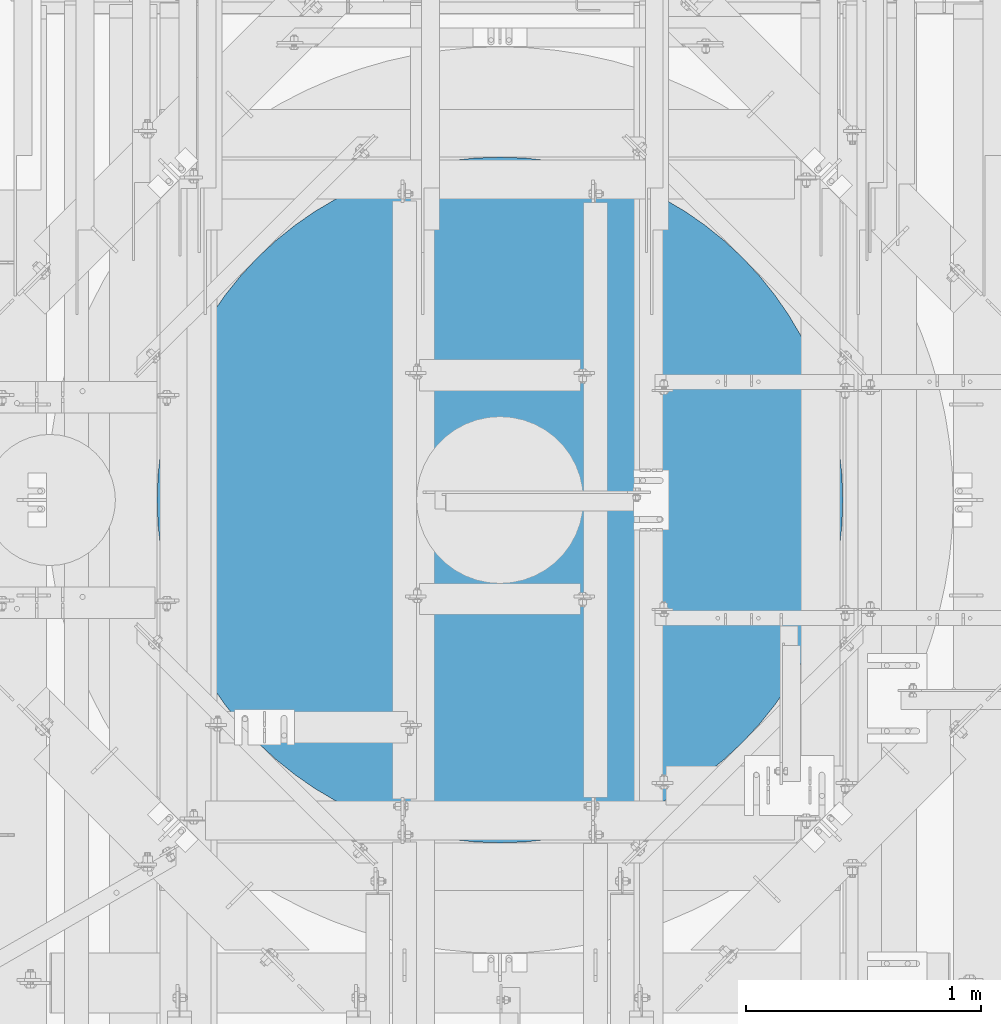
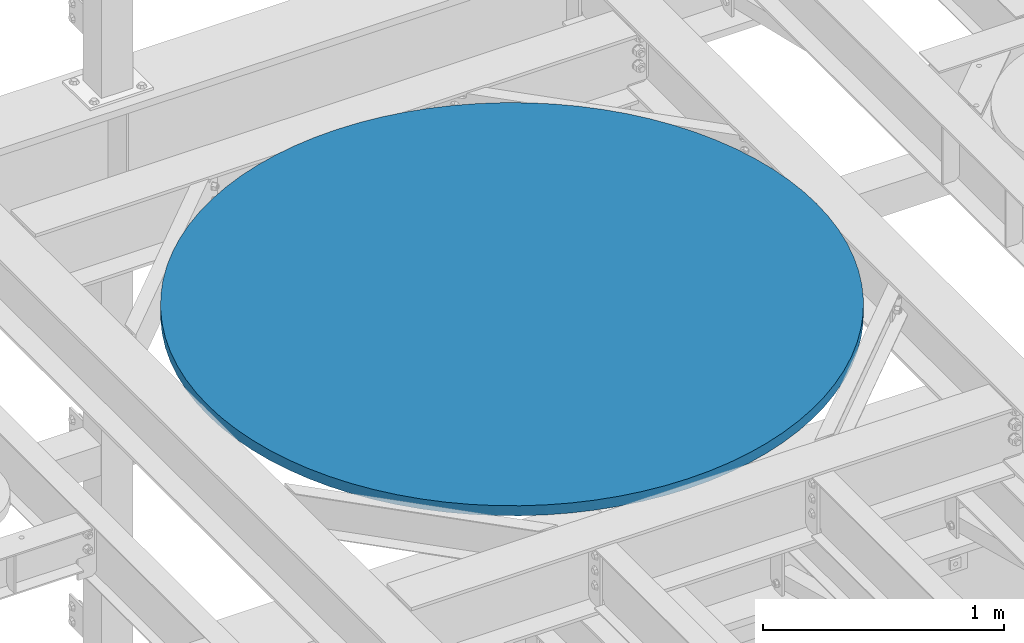
# One storey, part 744 of 1876: 1 column, 1 element without a shape of its own.
"""IFC2X3 building model written with IfcOpenShell, lengths in millimetres."""

from ifc_helpers import new_model, si_unit, frame, origin_with_axes, place, context, subcontext, project, spatial, faceted_brep, material, type_object, element, aggregate, save


model = new_model("IFC2X3")

# Units and contexts
model_context = context("Model", 3, precision=1e-05, world=origin_with_axes())
body_context = subcontext(model_context, "Body", "Model", "MODEL_VIEW")
ifc_project = project(units=[si_unit("LENGTHUNIT", "METRE", prefix="MILLI"), si_unit("AREAUNIT", "SQUARE_METRE"), si_unit("VOLUMEUNIT", "CUBIC_METRE"), si_unit("MASSUNIT", "GRAM", prefix="KILO"), si_unit("TIMEUNIT", "SECOND"), si_unit("PLANEANGLEUNIT", "RADIAN"), si_unit("SOLIDANGLEUNIT", "STERADIAN"), si_unit("THERMODYNAMICTEMPERATUREUNIT", "DEGREE_CELSIUS"), si_unit("LUMINOUSINTENSITYUNIT", "LUMEN")], contexts=[model_context])

# Site, building, storey
site_placement = place(None, origin_with_axes())
site = spatial("IfcSite", under=ifc_project, at=site_placement, CompositionType="ELEMENT")
building_placement = place(site_placement, origin_with_axes())
building = spatial("IfcBuilding", under=site, at=building_placement, Name="Undefined", CompositionType="ELEMENT")
storey_placement = place(building_placement, origin_with_axes())
storey = spatial("IfcBuildingStorey", under=building, at=storey_placement, Name="Undefined", CompositionType="ELEMENT", Elevation=0.0)

# Assembly, column
assembly_placement = place(storey_placement, origin_with_axes())
assembly = element("IfcElementAssembly", 1, at=assembly_placement, inside=storey, Name="COLUMN", AssemblyPlace="NOTDEFINED", PredefinedType="REINFORCEMENT_UNIT")
ifc_material = material(Name="CONCRETE/3000")
column_type = type_object("IfcColumnType", PredefinedType="NOTDEFINED")
column_placement = place(assembly_placement, frame((3187.7, 11480.8, 8128.0), z_axis=(-1.0, 0.0, 0.0), x_axis=(0.0, 0.0, 1.0)))
column = element("IfcColumn", 2, at=column_placement, type_object=column_type, material=ifc_material, Name="COLUMN", context=body_context, shape_type="Brep", body=[
    faceted_brep([(0.0, -1460.5, 0.0), (0.0, -1456.77881338828, -104.190877062479), (50.7999999999993, -1456.77881338828, -104.190877062479), (50.7999999999993, -1460.5, 0.0), (0.0, -1445.6342158671, -207.850821298133), (50.7999999999993, -1445.6342158671, -207.850821298133), (0.0, -1427.12299775088, -310.451605392123), (50.7999999999993, -1427.12299775088, -310.451605392123), (0.0, -1401.33948796397, -411.470399266908), (50.7999999999993, -1401.33948796397, -411.470399266908), (0.0, -1368.41507336215, -510.392434304484), (50.7999999999993, -1368.41507336215, -510.392434304484), (0.0, -1328.51752921527, -606.713626489255), (50.7999999999993, -1328.51752921527, -606.713626489255), (0.0, -1281.85016426298, -699.943145104643), (50.7999999999993, -1281.85016426298, -699.943145104643), (0.0, -1228.65078469994, -789.6059138939), (50.7999999999993, -1228.65078469994, -789.6059138939), (0.0, -1169.19048237003, -875.245031939823), (50.7999999999993, -1169.19048237003, -875.245031939823), (0.0, -1103.77225334439, -956.424101927088), (50.7999999999993, -1103.77225334439, -956.424101927088), (0.0, -1032.72945392295, -1032.72945392295), (50.7999999999993, -1032.72945392295, -1032.72945392295), (0.0, -956.424101927088, -1103.77225334439), (50.7999999999993, -956.424101927088, -1103.77225334439), (0.0, -875.245031939821, -1169.19048237003), (50.7999999999993, -875.245031939821, -1169.19048237003), (0.0, -789.6059138939, -1228.65078469994), (50.7999999999993, -789.6059138939, -1228.65078469994), (0.0, -699.943145104642, -1281.85016426298), (50.7999999999993, -699.943145104642, -1281.85016426298), (0.0, -606.713626489254, -1328.51752921527), (50.7999999999993, -606.713626489254, -1328.51752921527), (0.0, -510.392434304484, -1368.41507336215), (50.7999999999993, -510.392434304484, -1368.41507336215), (0.0, -411.470399266907, -1401.33948796397), (50.7999999999993, -411.470399266907, -1401.33948796397), (0.0, -310.451605392123, -1427.12299775088), (50.7999999999993, -310.451605392123, -1427.12299775088), (0.0, -207.850821298132, -1445.6342158671), (50.7999999999993, -207.850821298132, -1445.6342158671), (0.0, -104.19087706248, -1456.77881338828), (50.7999999999993, -104.19087706248, -1456.77881338828), (0.0, 0.0, -1460.5), (50.7999999999993, 0.0, -1460.5), (0.0, 104.190877062478, -1456.77881338828), (50.7999999999993, 104.190877062478, -1456.77881338828), (0.0, 207.850821298132, -1445.6342158671), (50.7999999999993, 207.850821298132, -1445.6342158671), (0.0, 310.451605392123, -1427.12299775088), (50.7999999999993, 310.451605392123, -1427.12299775088), (0.0, 411.470399266907, -1401.33948796397), (50.7999999999993, 411.470399266907, -1401.33948796397), (0.0, 510.392434304484, -1368.41507336215), (50.7999999999993, 510.392434304484, -1368.41507336215), (0.0, 606.713626489254, -1328.51752921527), (50.7999999999993, 606.713626489254, -1328.51752921527), (0.0, 699.943145104644, -1281.85016426298), (50.7999999999993, 699.943145104644, -1281.85016426298), (0.0, 789.6059138939, -1228.65078469994), (50.7999999999993, 789.6059138939, -1228.65078469994), (0.0, 875.245031939823, -1169.19048237003), (50.7999999999993, 875.245031939823, -1169.19048237003), (0.0, 956.424101927088, -1103.77225334439), (50.7999999999993, 956.424101927088, -1103.77225334439), (0.0, 1032.72945392295, -1032.72945392295), (50.7999999999993, 1032.72945392295, -1032.72945392295), (0.0, 1103.77225334439, -956.424101927088), (50.7999999999993, 1103.77225334439, -956.424101927088), (0.0, 1169.19048237003, -875.245031939822), (50.7999999999993, 1169.19048237003, -875.245031939822), (0.0, 1228.65078469994, -789.6059138939), (50.7999999999993, 1228.65078469994, -789.6059138939), (0.0, 1281.85016426298, -699.943145104643), (50.7999999999993, 1281.85016426298, -699.943145104643), (0.0, 1328.51752921527, -606.713626489255), (50.7999999999993, 1328.51752921527, -606.713626489255), (0.0, 1368.41507336215, -510.392434304483), (50.7999999999993, 1368.41507336215, -510.392434304483), (0.0, 1401.33948796397, -411.470399266907), (50.7999999999993, 1401.33948796397, -411.470399266907), (0.0, 1427.12299775088, -310.451605392122), (50.7999999999993, 1427.12299775088, -310.451605392122), (0.0, 1445.6342158671, -207.850821298133), (50.7999999999993, 1445.6342158671, -207.850821298133), (0.0, 1456.77881338828, -104.190877062479), (50.7999999999993, 1456.77881338828, -104.190877062479), (0.0, 1460.5, 0.0), (50.7999999999993, 1460.5, 0.0), (0.0, 1456.77881338828, 104.190877062479), (50.7999999999993, 1456.77881338828, 104.190877062479), (0.0, 1445.6342158671, 207.850821298133), (50.7999999999993, 1445.6342158671, 207.850821298133), (0.0, 1427.12299775088, 310.451605392122), (50.7999999999993, 1427.12299775088, 310.451605392122), (0.0, 1401.33948796397, 411.470399266908), (50.7999999999993, 1401.33948796397, 411.470399266908), (0.0, 1368.41507336215, 510.392434304483), (50.7999999999993, 1368.41507336215, 510.392434304483), (0.0, 1328.51752921527, 606.713626489255), (50.7999999999993, 1328.51752921527, 606.713626489255), (0.0, 1281.85016426298, 699.943145104643), (50.7999999999993, 1281.85016426298, 699.943145104643), (0.0, 1228.65078469994, 789.605913893901), (50.7999999999993, 1228.65078469994, 789.605913893901), (0.0, 1169.19048237003, 875.245031939822), (50.7999999999993, 1169.19048237003, 875.245031939822), (0.0, 1103.77225334439, 956.424101927089), (50.7999999999993, 1103.77225334439, 956.424101927089), (0.0, 1032.72945392295, 1032.72945392295), (50.7999999999993, 1032.72945392295, 1032.72945392295), (0.0, 956.424101927088, 1103.77225334439), (50.7999999999993, 956.424101927088, 1103.77225334439), (0.0, 875.245031939823, 1169.19048237003), (50.7999999999993, 875.245031939823, 1169.19048237003), (0.0, 789.6059138939, 1228.65078469994), (50.7999999999993, 789.6059138939, 1228.65078469994), (0.0, 699.943145104644, 1281.85016426298), (50.7999999999993, 699.943145104644, 1281.85016426298), (0.0, 606.713626489254, 1328.51752921527), (50.7999999999993, 606.713626489254, 1328.51752921527), (0.0, 510.392434304484, 1368.41507336215), (50.7999999999993, 510.392434304484, 1368.41507336215), (0.0, 411.470399266907, 1401.33948796397), (50.7999999999993, 411.470399266907, 1401.33948796397), (0.0, 310.451605392122, 1427.12299775088), (50.7999999999993, 310.451605392122, 1427.12299775088), (0.0, 207.850821298132, 1445.6342158671), (50.7999999999993, 207.850821298132, 1445.6342158671), (0.0, 104.19087706248, 1456.77881338828), (50.7999999999993, 104.19087706248, 1456.77881338828), (0.0, 0.0, 1460.5), (50.7999999999993, 0.0, 1460.5), (0.0, -104.19087706248, 1456.77881338828), (50.7999999999993, -104.19087706248, 1456.77881338828), (0.0, -207.850821298132, 1445.6342158671), (50.7999999999993, -207.850821298132, 1445.6342158671), (0.0, -310.451605392122, 1427.12299775088), (50.7999999999993, -310.451605392122, 1427.12299775088), (0.0, -411.470399266907, 1401.33948796397), (50.7999999999993, -411.470399266907, 1401.33948796397), (0.0, -510.392434304484, 1368.41507336215), (50.7999999999993, -510.392434304484, 1368.41507336215), (0.0, -606.713626489254, 1328.51752921527), (50.7999999999993, -606.713626489254, 1328.51752921527), (0.0, -699.943145104644, 1281.85016426298), (50.7999999999993, -699.943145104644, 1281.85016426298), (0.0, -789.6059138939, 1228.65078469994), (50.7999999999993, -789.6059138939, 1228.65078469994), (0.0, -875.245031939823, 1169.19048237003), (50.7999999999993, -875.245031939823, 1169.19048237003), (0.0, -956.424101927088, 1103.77225334439), (50.7999999999993, -956.424101927088, 1103.77225334439), (0.0, -1032.72945392295, 1032.72945392295), (50.7999999999993, -1032.72945392295, 1032.72945392295), (0.0, -1103.77225334439, 956.424101927089), (50.7999999999993, -1103.77225334439, 956.424101927089), (0.0, -1169.19048237003, 875.245031939822), (50.7999999999993, -1169.19048237003, 875.245031939822), (0.0, -1228.65078469994, 789.6059138939), (50.7999999999993, -1228.65078469994, 789.6059138939), (0.0, -1281.85016426298, 699.943145104643), (50.7999999999993, -1281.85016426298, 699.943145104643), (0.0, -1328.51752921527, 606.713626489255), (50.7999999999993, -1328.51752921527, 606.713626489255), (0.0, -1368.41507336215, 510.392434304483), (50.7999999999993, -1368.41507336215, 510.392434304483), (0.0, -1401.33948796397, 411.470399266908), (50.7999999999993, -1401.33948796397, 411.470399266908), (0.0, -1427.12299775088, 310.451605392122), (50.7999999999993, -1427.12299775088, 310.451605392122), (0.0, -1445.6342158671, 207.850821298133), (50.7999999999993, -1445.6342158671, 207.850821298133), (0.0, -1456.77881338828, 104.190877062479), (50.7999999999993, -1456.77881338828, 104.190877062479)], [[[0, 1, 2, 3]], [[1, 4, 5, 2]], [[4, 6, 7, 5]], [[6, 8, 9, 7]], [[8, 10, 11, 9]], [[10, 12, 13, 11]], [[12, 14, 15, 13]], [[14, 16, 17, 15]], [[16, 18, 19, 17]], [[18, 20, 21, 19]], [[20, 22, 23, 21]], [[22, 24, 25, 23]], [[24, 26, 27, 25]], [[26, 28, 29, 27]], [[28, 30, 31, 29]], [[30, 32, 33, 31]], [[32, 34, 35, 33]], [[34, 36, 37, 35]], [[36, 38, 39, 37]], [[38, 40, 41, 39]], [[40, 42, 43, 41]], [[42, 44, 45, 43]], [[44, 46, 47, 45]], [[46, 48, 49, 47]], [[48, 50, 51, 49]], [[50, 52, 53, 51]], [[52, 54, 55, 53]], [[54, 56, 57, 55]], [[56, 58, 59, 57]], [[58, 60, 61, 59]], [[60, 62, 63, 61]], [[62, 64, 65, 63]], [[64, 66, 67, 65]], [[66, 68, 69, 67]], [[68, 70, 71, 69]], [[70, 72, 73, 71]], [[72, 74, 75, 73]], [[74, 76, 77, 75]], [[76, 78, 79, 77]], [[78, 80, 81, 79]], [[80, 82, 83, 81]], [[82, 84, 85, 83]], [[84, 86, 87, 85]], [[86, 88, 89, 87]], [[88, 90, 91, 89]], [[90, 92, 93, 91]], [[92, 94, 95, 93]], [[94, 96, 97, 95]], [[96, 98, 99, 97]], [[98, 100, 101, 99]], [[100, 102, 103, 101]], [[102, 104, 105, 103]], [[104, 106, 107, 105]], [[106, 108, 109, 107]], [[108, 110, 111, 109]], [[110, 112, 113, 111]], [[112, 114, 115, 113]], [[114, 116, 117, 115]], [[116, 118, 119, 117]], [[118, 120, 121, 119]], [[120, 122, 123, 121]], [[122, 124, 125, 123]], [[124, 126, 127, 125]], [[126, 128, 129, 127]], [[128, 130, 131, 129]], [[130, 132, 133, 131]], [[132, 134, 135, 133]], [[134, 136, 137, 135]], [[136, 138, 139, 137]], [[138, 140, 141, 139]], [[140, 142, 143, 141]], [[142, 144, 145, 143]], [[144, 146, 147, 145]], [[146, 148, 149, 147]], [[148, 150, 151, 149]], [[150, 152, 153, 151]], [[152, 154, 155, 153]], [[154, 156, 157, 155]], [[156, 158, 159, 157]], [[158, 160, 161, 159]], [[160, 162, 163, 161]], [[162, 164, 165, 163]], [[164, 166, 167, 165]], [[166, 168, 169, 167]], [[168, 170, 171, 169]], [[170, 172, 173, 171]], [[172, 174, 175, 173]], [[174, 0, 3, 175]], [[5, 7, 9, 11, 13, 15, 17, 19, 21, 23, 25, 27, 29, 31, 33, 35, 37, 39, 41, 43, 45, 47, 49, 51, 53, 55, 57, 59, 61, 63, 65, 67, 69, 71, 73, 75, 77, 79, 81, 83, 85, 87, 89, 91, 93, 95, 97, 99, 101, 103, 105, 107, 109, 111, 113, 115, 117, 119, 121, 123, 125, 127, 129, 131, 133, 135, 137, 139, 141, 143, 145, 147, 149, 151, 153, 155, 157, 159, 161, 163, 165, 167, 169, 171, 173, 175, 3, 2]], [[174, 172, 170, 168, 166, 164, 162, 160, 158, 156, 154, 152, 150, 148, 146, 144, 142, 140, 138, 136, 134, 132, 130, 128, 126, 124, 122, 120, 118, 116, 114, 112, 110, 108, 106, 104, 102, 100, 98, 96, 94, 92, 90, 88, 86, 84, 82, 80, 78, 76, 74, 72, 70, 68, 66, 64, 62, 60, 58, 56, 54, 52, 50, 48, 46, 44, 42, 40, 38, 36, 34, 32, 30, 28, 26, 24, 22, 20, 18, 16, 14, 12, 10, 8, 6, 4, 1, 0]]]),
])
aggregate(assembly, [column])

save(model, "model.ifc")
